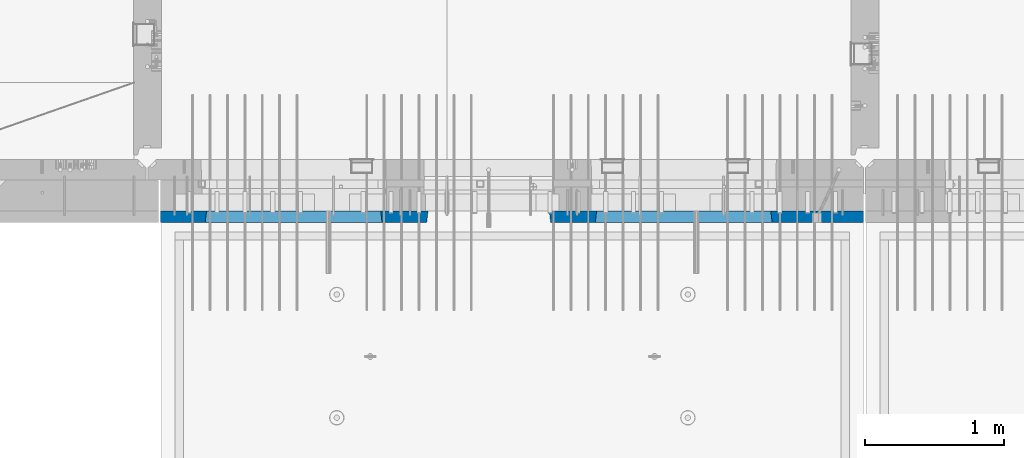
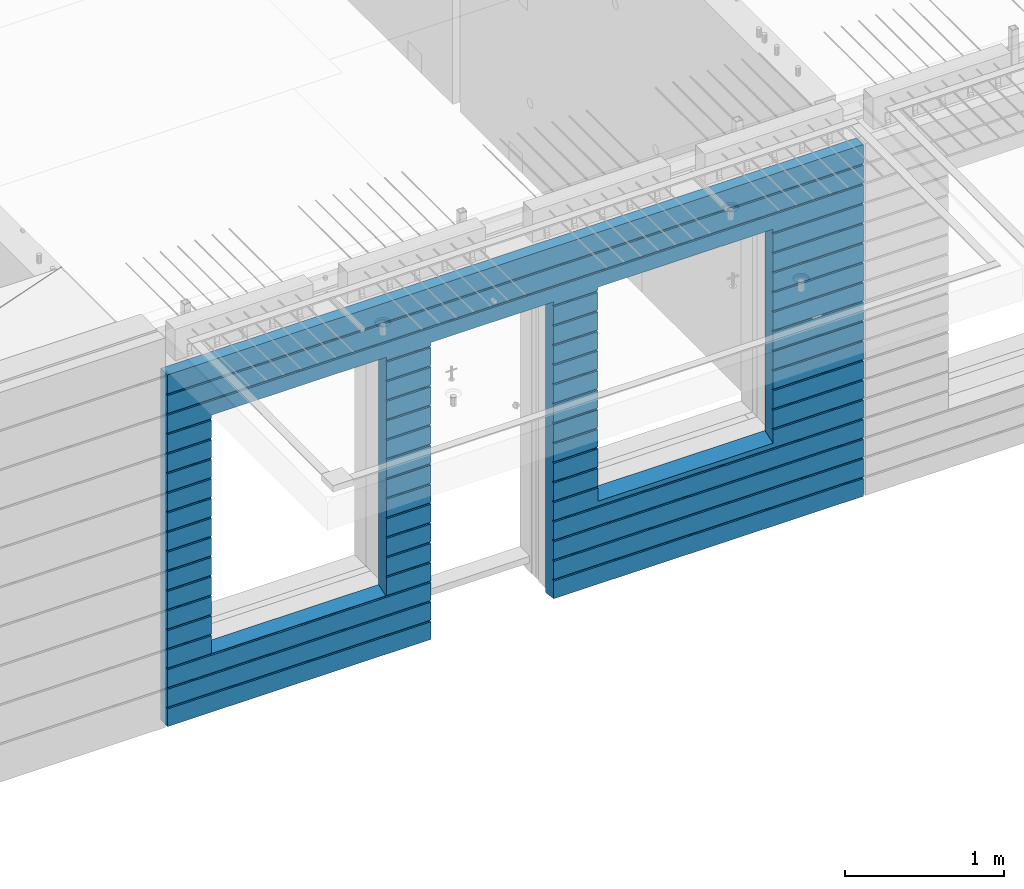
# One storey, part 230 of 349: 1 wall, 1 element without a shape of its own.
"""IFC2X3 building model written with IfcOpenShell, lengths in millimetres."""

import ifcopenshell
import ifcopenshell.guid

model = None  # the IFC model being written
_history = None  # IfcOwnerHistory: only IFC2X3 demands one
_inside = {}  # id of a spatial element -> (the spatial element, [elements in it])
_under = {}  # id of a project, library or spatial element -> (it, [spatial elements below it])
_declared = {}  # id of a project -> (the project, [libraries it declares])
_typed = {}  # id of a type object -> (the type object, [elements of that type])
_made_of = {}  # id of a material, layer set ... -> (it, [elements and type objects made of it])


def new_model(schema):
    """Start an empty IFC model of exactly this schema.

    Asked for "IFC4X3", IfcOpenShell would pick the latest addendum, in which some entities
    have other attributes; the version numbers below select the first issue.
    IFC2X3 requires an IfcOwnerHistory on every rooted entity: one is made here for all.
    """
    global model, _history
    if schema == "IFC4X3":
        model = ifcopenshell.file(schema_version=(4, 3, 0, 0))
    else:
        model = ifcopenshell.file(schema=schema)
    _inside.clear()
    _under.clear()
    _declared.clear()
    _typed.clear()
    _made_of.clear()
    _history = None
    if model.schema == "IFC2X3":
        org = make("IfcOrganization", Name="unknown")
        user = make(
            "IfcPersonAndOrganization",
            ThePerson=make("IfcPerson", FamilyName="unknown"),
            TheOrganization=org,
        )
        app = make(
            "IfcApplication",
            ApplicationDeveloper=org,
            Version="unknown",
            ApplicationFullName="unknown",
            ApplicationIdentifier="unknown",
        )
        _history = make(
            "IfcOwnerHistory",
            OwningUser=user,
            OwningApplication=app,
            ChangeAction="ADDED",
            CreationDate=0,
        )
    return model


def make(cls, **values):
    """One entity of the class cls with the attributes given. An attribute that is None is left unset."""
    return model.create_entity(
        cls, **{name: value for name, value in values.items() if value is not None}
    )


def rooted(cls, **values):
    """An entity with a GlobalId (a new one), such as an element, a storey or a relation."""
    return make(cls, GlobalId=ifcopenshell.guid.new(), OwnerHistory=_history, **values)


def si_unit(unit_type, name, prefix=None):
    """IfcSIUnit, for example si_unit("LENGTHUNIT", "METRE", prefix="MILLI")."""
    return make("IfcSIUnit", UnitType=unit_type, Prefix=prefix, Name=name)


def assignment(units):
    """IfcUnitAssignment: the units of a project."""
    return None if units is None else make("IfcUnitAssignment", Units=units)


def point(xyz):
    """IfcCartesianPoint."""
    return None if xyz is None else make("IfcCartesianPoint", Coordinates=xyz)


def direction(xyz):
    """IfcDirection."""
    return None if xyz is None else make("IfcDirection", DirectionRatios=xyz)


def frame(location, z_axis=None, x_axis=None):
    """IfcAxis2Placement3D, a coordinate frame: its origin and axes. An axis left out is left unset."""
    return make(
        "IfcAxis2Placement3D",
        Location=point(location),
        Axis=direction(z_axis),
        RefDirection=direction(x_axis),
    )


def origin_with_axes():
    """The frame at (0, 0, 0) with the z axis (0, 0, 1) and the x axis (1, 0, 0) written out."""
    return frame((0.0, 0.0, 0.0), z_axis=(0.0, 0.0, 1.0), x_axis=(1.0, 0.0, 0.0))


def place(relative_to, where):
    """IfcLocalPlacement: puts the frame where relative to a parent placement (None: the world)."""
    return make(
        "IfcLocalPlacement", PlacementRelTo=relative_to, RelativePlacement=where
    )


def context(
    kind, dimensions, precision=None, world=None, true_north=None, identifier=None
):
    """IfcGeometricRepresentationContext, for example the 3D "Model" context."""
    return make(
        "IfcGeometricRepresentationContext",
        ContextIdentifier=identifier,
        ContextType=kind,
        CoordinateSpaceDimension=dimensions,
        Precision=precision,
        WorldCoordinateSystem=world,
        TrueNorth=true_north,
    )


def subcontext(parent, identifier, kind, view, scale=None):
    """IfcGeometricRepresentationSubContext, for example "Body" below "Model"."""
    return make(
        "IfcGeometricRepresentationSubContext",
        ContextIdentifier=identifier,
        ContextType=kind,
        ParentContext=parent,
        TargetScale=scale,
        TargetView=view,
    )


def project(units=None, contexts=None):
    """IfcProject with its units and contexts."""
    return rooted(
        "IfcProject",
        Name="project",
        RepresentationContexts=contexts,
        UnitsInContext=assignment(units),
    )


def spatial(cls, under=None, at=None, **own):
    """A site, building, storey or space (cls), placed at a placement, below another one or the project."""
    s = rooted(cls, ObjectPlacement=at, **own)
    if under is not None:
        _under.setdefault(under.id(), (under, []))[1].append(s)
    return s


def faces_of(points, faces, orient=None, outer=None):
    """IfcFace entities. A face is a list of loops; a loop is a list of indices into points, from 0.

    orient and outer hold one flag for each loop. By default every Orientation is true, the
    first loop of a face is its IfcFaceOuterBound and the others are IfcFaceBound.
    """
    made = []
    for i, loops in enumerate(faces):
        bounds = []
        for j, loop in enumerate(loops):
            is_outer = j == 0 if outer is None else outer[i][j]
            bounds.append(
                make(
                    "IfcFaceOuterBound" if is_outer else "IfcFaceBound",
                    Bound=make("IfcPolyLoop", Polygon=[points[k] for k in loop]),
                    Orientation=True if orient is None else orient[i][j],
                )
            )
        made.append(make("IfcFace", Bounds=bounds))
    return made


def faceted_brep(points, faces, orient=None, outer=None, voids=None):
    """IfcFacetedBrep: a solid bounded by flat faces; with voids (closed shells), ...WithVoids."""
    shared = [point(p) for p in points]
    hull = make("IfcClosedShell", CfsFaces=faces_of(shared, faces, orient, outer))
    if voids is None:
        return make("IfcFacetedBrep", Outer=hull)
    return make(
        "IfcFacetedBrepWithVoids",
        Outer=hull,
        Voids=[
            make(cls, CfsFaces=faces_of(shared, fs, o, b)) for cls, fs, o, b in voids
        ],
    )


def shape(context_of_items, identifier, shape_type, items):
    """IfcShapeRepresentation: the items that make up one representation, for example the "Body"."""
    return make(
        "IfcShapeRepresentation",
        ContextOfItems=context_of_items,
        RepresentationIdentifier=identifier,
        RepresentationType=shape_type,
        Items=items,
    )


def material(Name=None, Category=None):
    """IfcMaterial."""
    return make("IfcMaterial", Name=Name, Category=Category)


def made_of(thing, what):
    """Note that an element or type object is made of a material, layer set ...; save() writes the relation."""
    if what is not None:
        _made_of.setdefault(what.id(), (what, []))[1].append(thing)
    return thing


def type_object(cls, material=None, **own):
    """A type object (cls), such as IfcWallType, which elements share."""
    return made_of(rooted(cls, **own), material)


def element(
    cls,
    number,
    at=None,
    inside=None,
    cuts=None,
    type_object=None,
    material=None,
    context=None,
    identifier="Body",
    shape_type=None,
    held_by="IfcProductDefinitionShape",
    body=None,
    shapes=None,
    **own,
):
    """One element of the class cls, such as IfcWall. Its Tag is "e" and its number.

    at: its placement. inside: the storey or other place that contains it. cuts: it is an
    opening in that element (IfcRelVoidsElement). A single representation is given by context,
    identifier, shape_type and body (its items); several are given by shapes. held_by: the class
    of the entity that holds the representations. save() writes the other relations.
    """
    e = rooted(cls, Tag="e%d" % number, ObjectPlacement=at, **own)
    if body is not None:
        shapes = [shape(context, identifier, shape_type, body)]
    if shapes is not None:
        e.Representation = make(held_by, Representations=shapes)
    if inside is not None:
        _inside.setdefault(inside.id(), (inside, []))[1].append(e)
    if cuts is not None:
        rooted(
            "IfcRelVoidsElement", RelatingBuildingElement=cuts, RelatedOpeningElement=e
        )
    if type_object is not None:
        _typed.setdefault(type_object.id(), (type_object, []))[1].append(e)
    return made_of(e, material)


def aggregate(whole, parts):
    """IfcRelAggregates: a whole, such as a stair, and the parts it consists of."""
    return rooted("IfcRelAggregates", RelatingObject=whole, RelatedObjects=parts)


def save(model, path):
    """Write the relations noted so far, then the file.

    IfcRelAggregates (storeys below a building ...), IfcRelContainedInSpatialStructure (elements
    in a storey), IfcRelDefinesByType, IfcRelAssociatesMaterial and IfcRelDeclares: one each for
    every whole, place, type object, material and project.
    """
    for whole, parts in _under.values():
        aggregate(whole, parts)
    for where, things in _inside.values():
        rooted(
            "IfcRelContainedInSpatialStructure",
            RelatedElements=things,
            RelatingStructure=where,
        )
    for kind, things in _typed.values():
        rooted("IfcRelDefinesByType", RelatedObjects=things, RelatingType=kind)
    for what, things in _made_of.values():
        rooted("IfcRelAssociatesMaterial", RelatedObjects=things, RelatingMaterial=what)
    for by, libraries in _declared.values():
        rooted("IfcRelDeclares", RelatingContext=by, RelatedDefinitions=libraries)
    model.write(path)


model = new_model("IFC2X3")

# Units and contexts
model_context = context("Model", 3, precision=1e-05, world=origin_with_axes())
body_context = subcontext(model_context, "Body", "Model", "MODEL_VIEW")
ifc_project = project(units=[si_unit("LENGTHUNIT", "METRE", prefix="MILLI"), si_unit("AREAUNIT", "SQUARE_METRE"), si_unit("VOLUMEUNIT", "CUBIC_METRE"), si_unit("MASSUNIT", "GRAM", prefix="KILO"), si_unit("TIMEUNIT", "SECOND"), si_unit("PLANEANGLEUNIT", "RADIAN"), si_unit("SOLIDANGLEUNIT", "STERADIAN"), si_unit("THERMODYNAMICTEMPERATUREUNIT", "DEGREE_CELSIUS"), si_unit("LUMINOUSINTENSITYUNIT", "LUMEN")], contexts=[model_context])

# Site, building, storey
site_placement = place(None, origin_with_axes())
site = spatial("IfcSite", under=ifc_project, at=site_placement, CompositionType="ELEMENT")
building_placement = place(site_placement, origin_with_axes())
building = spatial("IfcBuilding", under=site, at=building_placement, CompositionType="ELEMENT")
storey_placement = place(building_placement, origin_with_axes())
storey = spatial("IfcBuildingStorey", under=building, at=storey_placement, Name="4", CompositionType="ELEMENT", Elevation=0.0)

# Assembly, wall
assembly_placement = place(storey_placement, origin_with_axes())
assembly = element("IfcElementAssembly", 1, at=assembly_placement, inside=storey, AssemblyPlace="NOTDEFINED", PredefinedType="REINFORCEMENT_UNIT")
ifc_material = material(Name="CONCRETE/C30/37")
wall_type = type_object("IfcWallType", PredefinedType="NOTDEFINED")
wall_placement = place(assembly_placement, frame((21810.0, 7587.5, 92102.5), z_axis=(0.0, 0.0, 1.0), x_axis=(-1.0, 3.00000001838171e-08, 0.0)))
wall = element("IfcWall", 2, at=wall_placement, type_object=wall_type, material=ifc_material, context=body_context, shape_type="Brep", body=[
    faceted_brep([(3465.15088791894, 41.2121213860573, -911.742424344746), (3464.99937278789, 42.5, -912.5), (3464.99937278789, 42.5, -912.000000055254), (4734.84785765683, 41.2121213860573, -911.742424344746), (4734.99937278789, 42.5, -912.5), (4734.99937278789, 42.5, -912.000000055254), (10.0, 42.5, -1347.5), (10.0, 42.5, -1212.00000005524), (2254.99845837354, 42.5, -1212.00000005524), (2254.99845837354, 42.5, -1347.5), (10.0, 32.4999992501662, -1210.00000000079), (2256.17512512844, 32.4999992501662, -1210.00000000079), (10.0000007500639, 32.499999249937, -1200.00000000079), (2256.17512514468, 32.4999991121731, -1199.99999959956), (10.0, 42.5, -1198.00000011075), (2254.99845837354, 42.5, -1198.00000011075), (10.0, 42.5, -1062.00000005522), (2254.99845837354, 42.5, -1062.00000005522), (10.0, 32.4999992506964, -1060.00000000079), (2256.17512512838, 32.4999992506964, -1060.00000000079), (10.0000007500657, 32.499999249937, -1050.00000000079), (2256.17512514461, 32.499999112697, -1049.99999959956), (10.0, 42.5, -1048.00000011074), (2254.99845837354, 42.5, -1048.00000011074), (10.0, 42.5, -912.000000055254), (2254.99845837354, 42.5, -912.000000055254), (10.0, 32.4999992512312, -910.000000000815), (2256.17512512832, 32.4999992512312, -910.000000000815), (10.0000007500657, 32.499999249937, -900.000000000786), (2256.17512514455, 32.4999991132318, -899.99999959959), (10.0, 42.5, -898.000000110769), (2254.99845837354, 42.5, -898.000000110769), (10.0, 42.5, -762.000000055225), (2254.99845837354, 42.5, -762.000000055225), (10.0, 32.4999992517696, -760.000000000771), (2256.17512512825, 32.4999992517696, -760.000000000771), (10.0000007500657, 32.499999249937, -750.000000000786), (2256.17512514449, 32.4999991137747, -749.999999599546), (10.0, 42.5, -748.00000011074), (2254.99845837354, 42.5, -748.00000011074), (675.00013572734, 42.5, 927.5), (1925.00013572734, 42.5, 927.5), (1935.00013572734, 42.5, 927.5), (1925.00013572734, -42.5, 932.5), (675.00013572734, -42.5, 932.5), (665.00013572734, 42.5, 927.5), (665.00013572734, 42.5, -712.5), (675.00013572734, -42.5, -662.5), (1925.00013572734, -42.5, -662.5), (1935.00013572734, 42.5, -712.5), (1925.00013572734, -42.5, 927.5), (1935.00013572734, 42.5, 901.999999889245), (1933.82366503463, 32.4999991119776, 900.000000400425), (1933.82366505087, 32.4999992499834, 889.9999999992), (1935.00013572734, 42.5, 887.999999944761), (1935.00013572734, 42.5, 751.999999889245), (1933.82366503463, 32.4999991119885, 750.000000400425), (1933.82366505087, 32.4999992499925, 739.9999999992), (1935.00013572734, 42.5, 737.999999944761), (1935.00013572734, 42.5, 601.99999988926), (1933.82366503463, 32.4999991120112, 600.00000040044), (1933.82366505087, 32.4999992500152, 589.999999999214), (1935.00013572734, 42.5, 587.999999944775), (1935.00013572734, 42.5, 451.999999889245), (1933.82366503464, 32.4999991120167, 450.000000400425), (1933.82366505087, 32.4999992500216, 439.9999999992), (1935.00013572734, 42.5, 437.999999944761), (1935.00013572734, 42.5, 301.999999889245), (1933.82366503464, 32.4999991120312, 300.000000400425), (1933.82366505087, 32.4999992500352, 289.9999999992), (1935.00013572734, 42.5, 287.999999944761), (1935.00013572734, 42.5, 151.999999889245), (1933.82366503464, 32.4999991120421, 150.000000400425), (1933.82366505088, 32.499999250047, 139.9999999992), (1935.00013572734, 42.5, 137.999999944761), (1935.00013572734, 42.5, 1.99999988923082), (1933.82366503515, 32.4999991164286, 4.00410499423742e-07), (1933.82366505139, 32.4999992544263, -10.0000000008149), (1935.00013572734, 42.5, -12.0000000552536), (1935.00013572734, 42.5, -148.000000110755), (1933.82366503509, 32.4999991158993, -149.99999959956), (1933.82366505132, 32.4999992538915, -160.000000000786), (1935.00013572734, 42.5, -162.000000055239), (1935.00013572734, 42.5, -298.000000110755), (1933.82366503503, 32.49999911536, -299.999999599575), (1933.82366505126, 32.4999992533594, -310.0000000008), (1935.00013572734, 42.5, -312.000000055239), (1935.00013572734, 42.5, -448.00000011074), (1933.82366503496, 32.4999991148343, -449.99999959956), (1933.8236650512, 32.4999992528337, -460.000000000786), (1935.00013572734, 42.5, -462.000000055225), (1935.00013572734, 42.5, -598.000000110755), (1933.8236650349, 32.499999114295, -599.999999599575), (1933.82366505114, 32.4999992522935, -610.0000000008), (1935.00013572734, 42.5, -612.000000055239), (2256.1751251447, 32.4999991119776, 900.000000400425), (2256.17512512846, 32.4999992499834, 889.9999999992), (2254.99845837354, 42.5, 887.999999944761), (2254.99845837354, 42.5, 751.999999889245), (2256.17512514469, 32.4999991119885, 750.000000400425), (2256.17512512846, 32.4999992499925, 739.9999999992), (2254.99845837354, 42.5, 737.999999944761), (2254.99845837354, 42.5, 601.99999988926), (2256.17512514469, 32.4999991120112, 600.00000040044), (2256.17512512846, 32.4999992500152, 589.999999999214), (2254.99845837354, 42.5, 587.999999944775), (2254.99845837354, 42.5, 451.999999889245), (2256.17512514469, 32.4999991120167, 450.000000400425), (2256.17512512846, 32.4999992500216, 439.9999999992), (2254.99845837354, 42.5, 437.999999944761), (2254.99845837354, 42.5, 301.999999889245), (2256.17512514469, 32.4999991120312, 300.000000400425), (2256.17512512846, 32.4999992500352, 289.9999999992), (2254.99845837354, 42.5, 287.999999944761), (2254.99845837354, 42.5, 151.999999889245), (2256.17512514469, 32.4999991120421, 150.000000400425), (2256.17512512846, 32.499999250047, 139.9999999992), (2254.99845837354, 42.5, 137.999999944761), (2254.99845837354, 42.5, 1.99999988923082), (2256.17512514417, 32.4999991164286, 4.00410499423742e-07), (2256.17512512794, 32.4999992544263, -10.0000000008149), (2254.99845837354, 42.5, -12.0000000552536), (2254.99845837354, 42.5, -148.000000110755), (2256.17512514424, 32.4999991158993, -149.99999959956), (2256.175125128, 32.4999992538915, -160.000000000786), (2254.99845837354, 42.5, -162.000000055239), (2254.99845837354, 42.5, -298.000000110755), (2256.1751251443, 32.49999911536, -299.999999599575), (2256.17512512806, 32.4999992533594, -310.0000000008), (2254.99845837354, 42.5, -312.000000055239), (2254.99845837354, 42.5, -448.00000011074), (2256.17512514436, 32.4999991148343, -449.99999959956), (2256.17512512813, 32.4999992528337, -460.000000000786), (2254.99845837354, 42.5, -462.000000055225), (2254.99845837354, 42.5, -598.000000110755), (2256.17512514443, 32.499999114295, -599.999999599575), (2256.17512512819, 32.4999992522935, -610.0000000008), (2254.99845837354, 42.5, -612.000000055239), (10.0, 42.5, -612.000000055239), (665.00013572734, 42.5, -612.000000055239), (10.0, 32.4999992522935, -610.0000000008), (666.176606403544, 32.4999992522935, -610.0000000008), (10.0000007500657, 32.499999249937, -600.000000000786), (666.176606419776, 32.499999114295, -599.999999599575), (10.0, 42.5, -598.000000110755), (665.00013572734, 42.5, -598.000000110755), (10.0, 42.5, -462.000000055225), (665.00013572734, 42.5, -462.000000055225), (10.0, 32.4999992528337, -460.000000000786), (666.176606403482, 32.4999992528337, -460.000000000786), (10.0000007500657, 32.499999249937, -450.000000000786), (666.176606419715, 32.4999991148343, -449.99999959956), (10.0, 42.5, -448.00000011074), (665.00013572734, 42.5, -448.00000011074), (10.0, 42.5, -312.000000055239), (665.00013572734, 42.5, -312.000000055239), (10.0, 32.4999992533594, -310.0000000008), (666.17660640342, 32.4999992533594, -310.0000000008), (10.0000007500657, 32.499999249937, -300.000000000786), (666.176606419653, 32.49999911536, -299.999999599575), (10.0, 42.5, -298.000000110755), (665.00013572734, 42.5, -298.000000110755), (10.0, 42.5, -162.000000055239), (665.00013572734, 42.5, -162.000000055239), (10.0, 32.4999992538915, -160.000000000786), (666.176606403355, 32.4999992538915, -160.000000000786), (10.0000007500657, 32.499999249937, -150.000000000786), (666.176606419591, 32.4999991158993, -149.99999959956), (10.0, 42.5, -148.000000110755), (665.00013572734, 42.5, -148.000000110755), (10.0, 42.5, -12.0000000552536), (665.00013572734, 42.5, -12.0000000552536), (10.0, 32.4999992544263, -10.0000000008149), (666.176606403293, 32.4999992544263, -10.0000000008149), (10.0000007500657, 32.499999249937, -7.8580342233181e-10), (666.176606419529, 32.4999991164286, 4.00410499423742e-07), (10.0, 42.5, 1.99999988923082), (665.00013572734, 42.5, 1.99999988923082), (10.0, 42.5, 137.999999944761), (665.00013572734, 42.5, 137.999999944761), (10.0, 32.499999250047, 139.9999999992), (666.176606403806, 32.499999250047, 139.9999999992), (10.0000007500657, 32.499999249937, 149.999999999214), (666.176606420046, 32.4999991120421, 150.000000400425), (10.0, 42.5, 151.999999889245), (665.00013572734, 42.5, 151.999999889245), (10.0, 42.5, 287.999999944761), (665.00013572734, 42.5, 287.999999944761), (10.0, 32.4999992500352, 289.9999999992), (666.176606403809, 32.4999992500352, 289.9999999992), (10.0000007500657, 32.499999249937, 299.999999999214), (666.176606420046, 32.4999991120312, 300.000000400425), (10.0, 42.5, 301.999999889245), (665.00013572734, 42.5, 301.999999889245), (10.0, 42.5, 437.999999944761), (665.00013572734, 42.5, 437.999999944761), (10.0, 32.4999992500216, 439.9999999992), (666.176606403809, 32.4999992500216, 439.9999999992), (10.0000007500657, 32.499999249937, 449.999999999214), (666.176606420046, 32.4999991120167, 450.000000400425), (10.0, 42.5, 451.999999889245), (665.00013572734, 42.5, 451.999999889245), (10.0, 42.5, 587.999999944775), (665.00013572734, 42.5, 587.999999944775), (10.0, 32.4999992500152, 589.999999999214), (666.176606403809, 32.4999992500152, 589.999999999214), (10.0000007500657, 32.499999249937, 599.999999999214), (666.176606420049, 32.4999991120112, 600.00000040044), (10.0, 42.5, 601.99999988926), (665.00013572734, 42.5, 601.99999988926), (10.0, 42.5, 737.999999944761), (665.00013572734, 42.5, 737.999999944761), (9.99999999999636, 32.4999992499925, 739.9999999992), (666.176606403813, 32.4999992499925, 739.9999999992), (10.0000007500657, 32.499999249937, 749.999999999214), (666.176606420049, 32.4999991119885, 750.000000400425), (10.0, 42.5, 751.999999889245), (665.00013572734, 42.5, 751.999999889245), (10.0, 42.5, 887.999999944761), (665.00013572734, 42.5, 887.999999944761), (10.0, 32.4999992499834, 889.9999999992), (666.176606403813, 32.4999992499834, 889.9999999992), (10.0000007500657, 32.499999249937, 899.999999999214), (666.176606420053, 32.4999991119776, 900.000000400425), (675.00013572734, -42.5, 927.5), (665.00013572734, 42.5, 901.999999889245), (10.0, 42.5, 901.999999889245), (10.0, 42.5, 1051.99999988925), (5055.0, 42.5, 1051.99999988925), (5055.0, 32.4999991119666, 1050.00000040043), (10.0000007500657, 32.499999249937, 1049.99999999921), (5055.0, 32.4999992499706, 1039.9999999992), (10.0, 32.4999992499706, 1039.9999999992), (5055.0, 42.5, 1037.99999994476), (10.0, 42.5, 1037.99999994476), (5055.0, 42.5, 901.999999889245), (5055.0, 32.4999991119776, 900.000000400425), (4733.82290209518, 32.4999991119776, 900.000000400425), (4734.99937278789, 42.5, 901.999999889245), (5055.0, 32.4999992499834, 889.9999999992), (4733.82290211141, 32.4999992499834, 889.9999999992), (5055.0, 42.5, 887.999999944761), (4734.99937278789, 42.5, 887.999999944761), (5055.0, 42.5, 751.999999889245), (4734.99937278789, 42.5, 751.999999889245), (5055.0, 32.4999991119885, 750.000000400425), (4733.82290209518, 32.4999991119885, 750.000000400425), (5055.0, 32.4999992499925, 739.9999999992), (4733.82290211142, 32.4999992499925, 739.9999999992), (5055.0, 42.5, 737.999999944761), (4734.99937278789, 42.5, 737.999999944761), (5055.0, 42.5, 601.99999988926), (4734.99937278789, 42.5, 601.99999988926), (5055.0, 32.4999991120112, 600.00000040044), (4733.82290209518, 32.4999991120112, 600.00000040044), (5055.0, 32.4999992500152, 589.999999999214), (4733.82290211142, 32.4999992500152, 589.999999999214), (5055.0, 42.5, 587.999999944775), (4734.99937278789, 42.5, 587.999999944775), (5055.0, 42.5, 451.999999889245), (4734.99937278789, 42.5, 451.999999889245), (5055.0, 32.4999991120167, 450.000000400425), (4733.82290209518, 32.4999991120167, 450.000000400425), (5055.0, 32.4999992500216, 439.9999999992), (4733.82290211142, 32.4999992500216, 439.9999999992), (5055.0, 42.5, 437.999999944761), (4734.99937278789, 42.5, 437.999999944761), (5055.0, 42.5, 301.999999889245), (4734.99937278789, 42.5, 301.999999889245), (5055.0, 32.4999991120312, 300.000000400425), (4733.82290209518, 32.4999991120312, 300.000000400425), (5055.0, 32.4999992500352, 289.9999999992), (4733.82290211142, 32.4999992500352, 289.9999999992), (5055.0, 42.5, 287.999999944761), (4734.99937278789, 42.5, 287.999999944761), (5055.0, 42.5, 151.999999889245), (4734.99937278789, 42.5, 151.999999889245), (5055.0, 32.4999991120421, 150.000000400425), (4733.82290209519, 32.4999991120421, 150.000000400425), (5055.0, 32.499999250047, 139.9999999992), (4733.82290211142, 32.499999250047, 139.9999999992), (5055.0, 42.5, 137.999999944761), (4734.99937278789, 42.5, 137.999999944761), (5055.0, 42.5, 1.99999988923082), (4734.99937278789, 42.5, 1.99999988923082), (5055.0, 32.4999991164286, 4.00410499423742e-07), (4733.8229020957, 32.4999991164286, 4.00410499423742e-07), (5055.0, 32.4999992544263, -10.0000000008149), (4733.82290211194, 32.4999992544263, -10.0000000008149), (5055.0, 42.5, -12.0000000552536), (4734.99937278789, 42.5, -12.0000000552536), (5055.0, 42.5, -148.000000110755), (4734.99937278789, 42.5, -148.000000110755), (5055.0, 32.4999991158993, -149.99999959956), (4733.82290209564, 32.4999991158993, -149.99999959956), (5055.0, 32.4999992538915, -160.000000000786), (4733.82290211188, 32.4999992538915, -160.000000000786), (5055.0, 42.5, -162.000000055239), (4734.99937278789, 42.5, -162.000000055239), (5055.0, 42.5, -298.000000110755), (4734.99937278789, 42.5, -298.000000110755), (5055.0, 32.49999911536, -299.999999599575), (4733.82290209558, 32.49999911536, -299.999999599575), (5055.0, 32.4999992533594, -310.0000000008), (4733.82290211181, 32.4999992533594, -310.0000000008), (5055.0, 42.5, -312.000000055239), (4734.99937278789, 42.5, -312.000000055239), (5055.0, 42.5, -448.00000011074), (4734.99937278789, 42.5, -448.00000011074), (5055.0, 32.4999991148343, -449.99999959956), (4733.82290209552, 32.4999991148343, -449.99999959956), (5055.0, 32.4999992528337, -460.000000000786), (4733.82290211175, 32.4999992528337, -460.000000000786), (5055.0, 42.5, -462.000000055225), (4734.99937278789, 42.5, -462.000000055225), (5055.0, 42.5, -598.000000110755), (4734.99937278789, 42.5, -598.000000110755), (5055.0, 32.499999114295, -599.999999599575), (4733.82290209545, 32.499999114295, -599.999999599575), (5055.0, 32.4999992522935, -610.0000000008), (4733.82290211169, 32.4999992522935, -610.0000000008), (5055.0, 42.5, -612.000000055239), (4734.99937278789, 42.5, -612.000000055239), (5055.0, 42.5, -748.00000011074), (4734.99937278789, 42.5, -748.00000011074), (5055.0, 32.4999991137747, -749.999999599546), (4733.82290209539, 32.4999991137747, -749.999999599546), (5055.0, 32.4999992517696, -760.000000000771), (4733.82290211162, 32.4999992517696, -760.000000000771), (5055.0, 42.5, -762.000000055225), (4734.99937278789, 42.5, -762.000000055225), (5055.0, 42.5, -898.000000110769), (4734.99937278789, 42.5, -898.000000110769), (5055.0, 32.4999991132318, -899.99999959959), (4733.82290209533, 32.4999991132318, -899.99999959959), (3466.1758434697, 32.499999204555, -906.617646590923), (3474.99937278789, -42.5, -862.5), (4724.99937278789, -42.5, -862.5), (4733.82290210607, 32.499999204555, -906.617646590923), (4724.99937278789, -42.5, 927.5), (4724.99937278789, -42.5, 932.5), (4734.99937278789, 42.5, 927.5), (2265.00051719707, 42.5, 927.5), (3135.00051719707, 42.5, 927.5), (3144.99845837354, 42.5, 927.5), (3134.99679170688, -42.5, 932.502857142856), (2265.00012504021, -42.5, 932.502857142856), (2254.99845837354, 42.5, 927.5), (4724.99937278789, 42.5, 927.5), (3474.99937278789, 42.5, 927.5), (3464.99937278789, 42.5, 927.5), (3464.99937278789, 42.5, 901.999999889245), (3144.99845837354, 42.5, 901.999999889245), (2254.99845837354, 42.5, 901.999999889245), (2265.00012504021, -42.5, 927.5), (2265.00012504021, -42.5, -1347.5), (10.0, -42.5, -1347.5), (10.0, 42.5, 1347.5), (10.0, -42.5, 1347.5), (5055.0, -42.5, 1347.5), (5055.0, 42.5, 1347.5), (5055.0, 42.5, 1201.99999988925), (10.0, 42.5, 1201.99999988925), (10.0, 42.5, 1187.99999994476), (10.0000007500657, 32.499999249937, 1199.99999999921), (9.99999999999636, 32.4999992499606, 1189.9999999992), (5055.0, 42.5, 1187.99999994476), (5055.0, 32.4999992499606, 1189.9999999992), (5055.0, 32.4999991119566, 1200.00000040043), (5055.0, -42.5, -1347.5), (5055.0, 42.5, -1347.5), (5055.0, 42.5, -1212.00000005524), (5055.0, 32.4999992501662, -1210.00000000079), (5055.0, 32.4999991121731, -1199.99999959956), (5055.0, 42.5, -1198.00000011075), (5055.0, 42.5, -1062.00000005522), (5055.0, 32.4999992506964, -1060.00000000079), (5055.0, 32.499999112697, -1049.99999959956), (5055.0, 42.5, -1048.00000011074), (5055.0, 42.5, -912.000000055254), (5055.0, 32.4999992512312, -910.000000000815), (3144.99845837354, 42.5, -1212.00000005524), (3143.82179161865, 32.4999992501662, -1210.00000000079), (3143.82179160241, 32.4999991121731, -1199.99999959956), (3144.99845837354, 42.5, -1198.00000011075), (3144.99845837354, 42.5, -1062.00000005522), (3143.82179161871, 32.4999992506964, -1060.00000000079), (3143.82179160247, 32.499999112697, -1049.99999959956), (3144.99845837354, 42.5, -1048.00000011074), (3144.99845837354, 42.5, -912.000000055254), (3143.82179161877, 32.4999992512312, -910.000000000815), (3466.17584348045, 32.4999991132318, -899.99999959959), (3143.82179160253, 32.4999991132318, -899.99999959959), (3464.99937278789, 42.5, -898.000000110769), (3144.99845837354, 42.5, -898.000000110769), (3464.99937278789, 42.5, -762.000000055225), (3144.99845837354, 42.5, -762.000000055225), (3466.17584346415, 32.4999992517696, -760.000000000771), (3143.82179161884, 32.4999992517696, -760.000000000771), (3466.17584348039, 32.4999991137747, -749.999999599546), (3143.8217916026, 32.4999991137747, -749.999999599546), (3464.99937278789, 42.5, -748.00000011074), (3144.99845837354, 42.5, -748.00000011074), (3464.99937278789, 42.5, -612.000000055239), (3144.99845837354, 42.5, -612.000000055239), (3466.17584346409, 32.4999992522935, -610.0000000008), (3143.8217916189, 32.4999992522935, -610.0000000008), (3466.17584348032, 32.499999114295, -599.999999599575), (3143.82179160266, 32.499999114295, -599.999999599575), (3464.99937278789, 42.5, -598.000000110755), (3144.99845837354, 42.5, -598.000000110755), (3464.99937278789, 42.5, -462.000000055225), (3144.99845837354, 42.5, -462.000000055225), (3466.17584346403, 32.4999992528337, -460.000000000786), (3143.82179161896, 32.4999992528337, -460.000000000786), (3466.17584348026, 32.4999991148343, -449.99999959956), (3143.82179160272, 32.4999991148343, -449.99999959956), (3464.99937278789, 42.5, -448.00000011074), (3144.99845837354, 42.5, -448.00000011074), (3464.99937278789, 42.5, -312.000000055239), (3144.99845837354, 42.5, -312.000000055239), (3466.17584346396, 32.4999992533594, -310.0000000008), (3143.82179161902, 32.4999992533594, -310.0000000008), (3466.1758434802, 32.49999911536, -299.999999599575), (3143.82179160278, 32.49999911536, -299.999999599575), (3464.99937278789, 42.5, -298.000000110755), (3144.99845837354, 42.5, -298.000000110755), (3464.99937278789, 42.5, -162.000000055239), (3144.99845837354, 42.5, -162.000000055239), (3466.1758434639, 32.4999992538915, -160.000000000786), (3143.82179161909, 32.4999992538915, -160.000000000786), (3466.17584348014, 32.4999991158993, -149.99999959956), (3143.82179160284, 32.4999991158993, -149.99999959956), (3464.99937278789, 42.5, -148.000000110755), (3144.99845837354, 42.5, -148.000000110755), (3464.99937278789, 42.5, -12.0000000552536), (3144.99845837354, 42.5, -12.0000000552536), (3466.17584346384, 32.4999992544263, -10.0000000008149), (3143.82179161915, 32.4999992544263, -10.0000000008149), (3466.17584348008, 32.4999991164286, 4.00410499423742e-07), (3143.82179160291, 32.4999991164286, 4.00410499423742e-07), (3464.99937278789, 42.5, 1.99999988923082), (3144.99845837354, 42.5, 1.99999988923082), (3464.99937278789, 42.5, 137.999999944761), (3144.99845837354, 42.5, 137.999999944761), (3466.17584346435, 32.499999250047, 139.9999999992), (3143.82179161863, 32.499999250047, 139.9999999992), (3466.17584348059, 32.4999991120421, 150.000000400425), (3143.82179160239, 32.4999991120421, 150.000000400425), (3464.99937278789, 42.5, 151.999999889245), (3144.99845837354, 42.5, 151.999999889245), (3464.99937278789, 42.5, 287.999999944761), (3144.99845837354, 42.5, 287.999999944761), (3466.17584346436, 32.4999992500352, 289.9999999992), (3143.82179161863, 32.4999992500352, 289.9999999992), (3466.17584348059, 32.4999991120312, 300.000000400425), (3143.82179160239, 32.4999991120312, 300.000000400425), (3464.99937278789, 42.5, 301.999999889245), (3144.99845837354, 42.5, 301.999999889245), (3464.99937278789, 42.5, 437.999999944761), (3144.99845837354, 42.5, 437.999999944761), (3466.17584346436, 32.4999992500216, 439.9999999992), (3143.82179161863, 32.4999992500216, 439.9999999992), (3466.17584348059, 32.4999991120167, 450.000000400425), (3143.82179160239, 32.4999991120167, 450.000000400425), (3464.99937278789, 42.5, 451.999999889245), (3144.99845837354, 42.5, 451.999999889245), (3464.99937278789, 42.5, 587.999999944775), (3144.99845837354, 42.5, 587.999999944775), (3466.17584346436, 32.4999992500152, 589.999999999214), (3143.82179161863, 32.4999992500152, 589.999999999214), (3466.1758434806, 32.4999991120112, 600.00000040044), (3143.82179160239, 32.4999991120112, 600.00000040044), (3464.99937278789, 42.5, 601.99999988926), (3144.99845837354, 42.5, 601.99999988926), (3464.99937278789, 42.5, 737.999999944761), (3144.99845837354, 42.5, 737.999999944761), (3466.17584346436, 32.4999992499925, 739.9999999992), (3143.82179161863, 32.4999992499925, 739.9999999992), (3466.1758434806, 32.4999991119885, 750.000000400425), (3143.82179160239, 32.4999991119885, 750.000000400425), (3464.99937278789, 42.5, 751.999999889245), (3144.99845837354, 42.5, 751.999999889245), (3464.99937278789, 42.5, 887.999999944761), (3144.99845837354, 42.5, 887.999999944761), (3466.17584346436, 32.4999992499834, 889.9999999992), (3143.82179161863, 32.4999992499834, 889.9999999992), (3466.1758434806, 32.4999991119776, 900.000000400425), (3143.82179160239, 32.4999991119776, 900.000000400425), (3474.99937278789, -42.5, 932.5), (3474.99937278789, -42.5, 927.5), (3134.99679170688, -42.5, 927.5), (3134.99679170688, -42.5, -1347.5), (3144.99845837354, 42.5, -1347.5)], [[[0, 1, 2]], [[3, 4, 1, 0]], [[5, 4, 3]], [[6, 7, 8, 9]], [[7, 10, 11, 8]], [[10, 12, 13, 11]], [[12, 14, 15, 13]], [[14, 16, 17, 15]], [[16, 18, 19, 17]], [[18, 20, 21, 19]], [[20, 22, 23, 21]], [[22, 24, 25, 23]], [[24, 26, 27, 25]], [[26, 28, 29, 27]], [[28, 30, 31, 29]], [[30, 32, 33, 31]], [[32, 34, 35, 33]], [[34, 36, 37, 35]], [[36, 38, 39, 37]], [[40, 41, 42, 43, 44, 45]], [[46, 47, 48, 49]], [[50, 43, 42, 51, 52, 53, 54, 55, 56, 57, 58, 59, 60, 61, 62, 63, 64, 65, 66, 67, 68, 69, 70, 71, 72, 73, 74, 75, 76, 77, 78, 79, 80, 81, 82, 83, 84, 85, 86, 87, 88, 89, 90, 91, 92, 93, 94, 49, 48]], [[53, 52, 95, 96]], [[54, 53, 96, 97]], [[55, 54, 97, 98]], [[56, 55, 98, 99]], [[57, 56, 99, 100]], [[58, 57, 100, 101]], [[59, 58, 101, 102]], [[60, 59, 102, 103]], [[61, 60, 103, 104]], [[62, 61, 104, 105]], [[63, 62, 105, 106]], [[64, 63, 106, 107]], [[65, 64, 107, 108]], [[66, 65, 108, 109]], [[67, 66, 109, 110]], [[68, 67, 110, 111]], [[69, 68, 111, 112]], [[70, 69, 112, 113]], [[71, 70, 113, 114]], [[72, 71, 114, 115]], [[73, 72, 115, 116]], [[74, 73, 116, 117]], [[75, 74, 117, 118]], [[76, 75, 118, 119]], [[77, 76, 119, 120]], [[78, 77, 120, 121]], [[79, 78, 121, 122]], [[80, 79, 122, 123]], [[81, 80, 123, 124]], [[82, 81, 124, 125]], [[83, 82, 125, 126]], [[84, 83, 126, 127]], [[85, 84, 127, 128]], [[86, 85, 128, 129]], [[87, 86, 129, 130]], [[88, 87, 130, 131]], [[89, 88, 131, 132]], [[90, 89, 132, 133]], [[91, 90, 133, 134]], [[92, 91, 134, 135]], [[93, 92, 135, 136]], [[94, 93, 136, 137]], [[38, 138, 139, 46, 49, 94, 137, 39]], [[138, 140, 141, 139]], [[140, 142, 143, 141]], [[142, 144, 145, 143]], [[144, 146, 147, 145]], [[146, 148, 149, 147]], [[148, 150, 151, 149]], [[150, 152, 153, 151]], [[152, 154, 155, 153]], [[154, 156, 157, 155]], [[156, 158, 159, 157]], [[158, 160, 161, 159]], [[160, 162, 163, 161]], [[162, 164, 165, 163]], [[164, 166, 167, 165]], [[166, 168, 169, 167]], [[168, 170, 171, 169]], [[170, 172, 173, 171]], [[172, 174, 175, 173]], [[174, 176, 177, 175]], [[176, 178, 179, 177]], [[178, 180, 181, 179]], [[180, 182, 183, 181]], [[182, 184, 185, 183]], [[184, 186, 187, 185]], [[186, 188, 189, 187]], [[188, 190, 191, 189]], [[190, 192, 193, 191]], [[192, 194, 195, 193]], [[194, 196, 197, 195]], [[196, 198, 199, 197]], [[198, 200, 201, 199]], [[200, 202, 203, 201]], [[202, 204, 205, 203]], [[204, 206, 207, 205]], [[206, 208, 209, 207]], [[208, 210, 211, 209]], [[210, 212, 213, 211]], [[212, 214, 215, 213]], [[214, 216, 217, 215]], [[216, 218, 219, 217]], [[218, 220, 221, 219]], [[220, 222, 223, 221]], [[45, 44, 224, 47, 46, 139, 141, 143, 145, 147, 149, 151, 153, 155, 157, 159, 161, 163, 165, 167, 169, 171, 173, 175, 177, 179, 181, 183, 185, 187, 189, 191, 193, 195, 197, 199, 201, 203, 205, 207, 209, 211, 213, 215, 217, 219, 221, 223, 225]], [[222, 226, 225, 223]], [[227, 228, 229, 230]], [[230, 229, 231, 232]], [[232, 231, 233, 234]], [[235, 236, 237, 238]], [[236, 239, 240, 237]], [[239, 241, 242, 240]], [[241, 243, 244, 242]], [[243, 245, 246, 244]], [[245, 247, 248, 246]], [[247, 249, 250, 248]], [[249, 251, 252, 250]], [[251, 253, 254, 252]], [[253, 255, 256, 254]], [[255, 257, 258, 256]], [[257, 259, 260, 258]], [[259, 261, 262, 260]], [[261, 263, 264, 262]], [[263, 265, 266, 264]], [[265, 267, 268, 266]], [[267, 269, 270, 268]], [[269, 271, 272, 270]], [[271, 273, 274, 272]], [[273, 275, 276, 274]], [[275, 277, 278, 276]], [[277, 279, 280, 278]], [[279, 281, 282, 280]], [[281, 283, 284, 282]], [[283, 285, 286, 284]], [[285, 287, 288, 286]], [[287, 289, 290, 288]], [[289, 291, 292, 290]], [[291, 293, 294, 292]], [[293, 295, 296, 294]], [[295, 297, 298, 296]], [[297, 299, 300, 298]], [[299, 301, 302, 300]], [[301, 303, 304, 302]], [[303, 305, 306, 304]], [[305, 307, 308, 306]], [[307, 309, 310, 308]], [[309, 311, 312, 310]], [[311, 313, 314, 312]], [[313, 315, 316, 314]], [[315, 317, 318, 316]], [[317, 319, 320, 318]], [[319, 321, 322, 320]], [[321, 323, 324, 322]], [[323, 325, 326, 324]], [[325, 327, 328, 326]], [[327, 329, 330, 328]], [[329, 331, 332, 330]], [[331, 333, 334, 332]], [[335, 336, 337, 338]], [[339, 340, 341, 238, 237, 240, 242, 244, 246, 248, 250, 252, 254, 256, 258, 260, 262, 264, 266, 268, 270, 272, 274, 276, 278, 280, 282, 284, 286, 288, 290, 292, 294, 296, 298, 300, 302, 304, 306, 308, 310, 312, 314, 316, 318, 320, 322, 324, 326, 328, 330, 332, 334, 338, 337]], [[342, 343, 344, 345, 346, 347]], [[51, 42, 41, 40, 45, 225, 226, 234, 233, 235, 238, 341, 348, 349, 350, 351, 352, 344, 343, 342, 347, 353]], [[52, 51, 353, 95]], [[347, 346, 354, 355, 9, 8, 11, 13, 15, 17, 19, 21, 23, 25, 27, 29, 31, 33, 35, 37, 39, 137, 136, 135, 134, 133, 132, 131, 130, 129, 128, 127, 126, 125, 124, 123, 122, 121, 120, 119, 118, 117, 116, 115, 114, 113, 112, 111, 110, 109, 108, 107, 106, 105, 104, 103, 102, 101, 100, 99, 98, 97, 96, 95, 353]], [[356, 6, 9, 355]], [[357, 358, 359, 360]], [[357, 360, 361, 362]], [[363, 227, 230, 232, 234, 226, 222, 220, 218, 216, 214, 212, 210, 208, 206, 204, 202, 200, 198, 196, 194, 192, 190, 188, 186, 184, 182, 180, 178, 176, 174, 172, 170, 168, 166, 164, 162, 160, 158, 156, 154, 152, 150, 148, 146, 144, 142, 140, 138, 38, 36, 34, 32, 30, 28, 26, 24, 22, 20, 18, 16, 14, 12, 10, 7, 6, 356, 358, 357, 362, 364, 365]], [[228, 227, 363, 366]], [[365, 367, 366, 363]], [[364, 368, 367, 365]], [[362, 361, 368, 364]], [[360, 359, 369, 370, 371, 372, 373, 374, 375, 376, 377, 378, 379, 380, 333, 331, 329, 327, 325, 323, 321, 319, 317, 315, 313, 311, 309, 307, 305, 303, 301, 299, 297, 295, 293, 291, 289, 287, 285, 283, 281, 279, 277, 275, 273, 271, 269, 267, 265, 263, 261, 259, 257, 255, 253, 251, 249, 247, 245, 243, 241, 239, 236, 235, 233, 231, 229, 228, 366, 367, 368, 361]], [[372, 371, 381, 382]], [[373, 372, 382, 383]], [[374, 373, 383, 384]], [[375, 374, 384, 385]], [[376, 375, 385, 386]], [[377, 376, 386, 387]], [[378, 377, 387, 388]], [[2, 1, 4, 5, 379, 378, 388, 389]], [[380, 379, 5, 3, 0, 2, 389, 390]], [[391, 335, 338, 334, 333, 380, 390, 392]], [[393, 391, 392, 394]], [[395, 393, 394, 396]], [[397, 395, 396, 398]], [[399, 397, 398, 400]], [[401, 399, 400, 402]], [[403, 401, 402, 404]], [[405, 403, 404, 406]], [[407, 405, 406, 408]], [[409, 407, 408, 410]], [[411, 409, 410, 412]], [[413, 411, 412, 414]], [[415, 413, 414, 416]], [[417, 415, 416, 418]], [[419, 417, 418, 420]], [[421, 419, 420, 422]], [[423, 421, 422, 424]], [[425, 423, 424, 426]], [[427, 425, 426, 428]], [[429, 427, 428, 430]], [[431, 429, 430, 432]], [[433, 431, 432, 434]], [[435, 433, 434, 436]], [[437, 435, 436, 438]], [[439, 437, 438, 440]], [[441, 439, 440, 442]], [[443, 441, 442, 444]], [[445, 443, 444, 446]], [[447, 445, 446, 448]], [[449, 447, 448, 450]], [[451, 449, 450, 452]], [[453, 451, 452, 454]], [[455, 453, 454, 456]], [[457, 455, 456, 458]], [[459, 457, 458, 460]], [[461, 459, 460, 462]], [[463, 461, 462, 464]], [[465, 463, 464, 466]], [[467, 465, 466, 468]], [[469, 467, 468, 470]], [[471, 469, 470, 472]], [[473, 471, 472, 474]], [[475, 473, 474, 476]], [[477, 475, 476, 478]], [[479, 477, 478, 480]], [[481, 479, 480, 482]], [[483, 481, 482, 484]], [[485, 483, 484, 486]], [[487, 485, 486, 488]], [[351, 487, 488, 352]], [[350, 489, 490, 336, 335, 391, 393, 395, 397, 399, 401, 403, 405, 407, 409, 411, 413, 415, 417, 419, 421, 423, 425, 427, 429, 431, 433, 435, 437, 439, 441, 443, 445, 447, 449, 451, 453, 455, 457, 459, 461, 463, 465, 467, 469, 471, 473, 475, 477, 479, 481, 483, 485, 487, 351]], [[349, 348, 341, 340, 489, 350]], [[491, 492, 369, 359, 358, 356, 355, 354, 346, 345], [339, 337, 336, 490, 489, 340], [50, 48, 47, 224, 44, 43]], [[370, 369, 492, 493]], [[491, 345, 344, 352, 488, 486, 484, 482, 480, 478, 476, 474, 472, 470, 468, 466, 464, 462, 460, 458, 456, 454, 452, 450, 448, 446, 444, 442, 440, 438, 436, 434, 432, 430, 428, 426, 424, 422, 420, 418, 416, 414, 412, 410, 408, 406, 404, 402, 400, 398, 396, 394, 392, 390, 389, 388, 387, 386, 385, 384, 383, 382, 381, 493, 492]], [[371, 370, 493, 381]]]),
])
aggregate(assembly, [wall])

save(model, "model.ifc")
